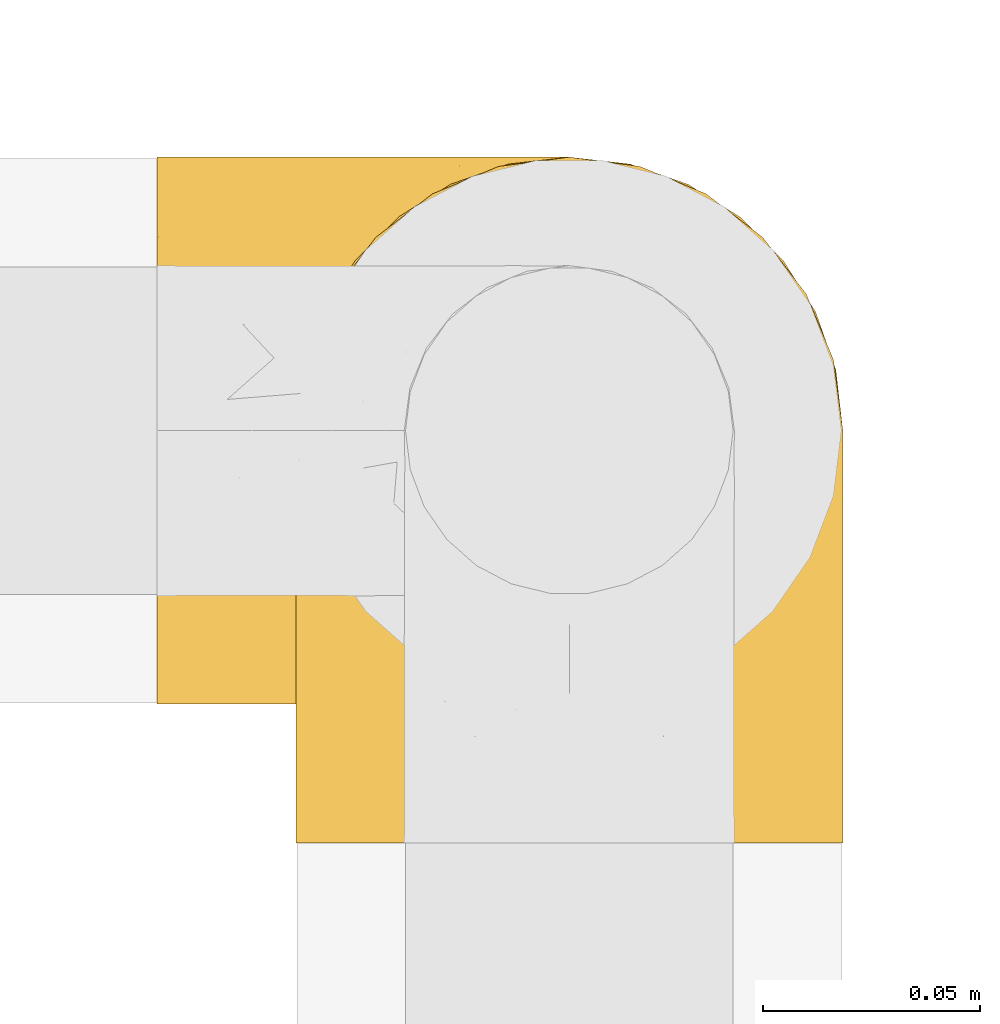
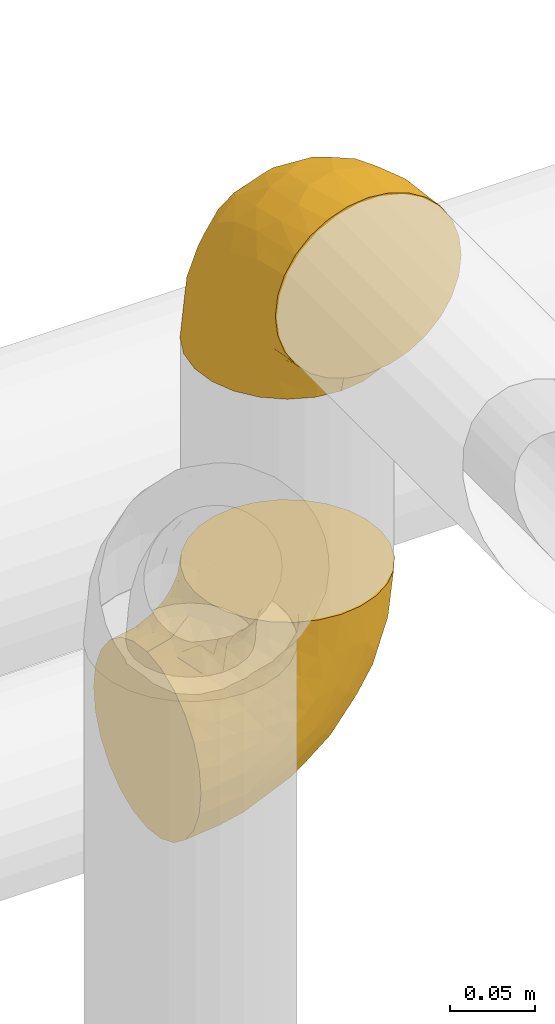
# One storey, part 122 of 827: 2 coverings.
"""IFC2X3 building model written with IfcOpenShell, lengths in millimetres."""

import ifcopenshell
import ifcopenshell.guid

model = None  # the IFC model being written
_history = None  # IfcOwnerHistory: only IFC2X3 demands one
_inside = {}  # id of a spatial element -> (the spatial element, [elements in it])
_under = {}  # id of a project, library or spatial element -> (it, [spatial elements below it])
_declared = {}  # id of a project -> (the project, [libraries it declares])
_typed = {}  # id of a type object -> (the type object, [elements of that type])
_made_of = {}  # id of a material, layer set ... -> (it, [elements and type objects made of it])


def new_model(schema):
    """Start an empty IFC model of exactly this schema.

    Asked for "IFC4X3", IfcOpenShell would pick the latest addendum, in which some entities
    have other attributes; the version numbers below select the first issue.
    IFC2X3 requires an IfcOwnerHistory on every rooted entity: one is made here for all.
    """
    global model, _history
    if schema == "IFC4X3":
        model = ifcopenshell.file(schema_version=(4, 3, 0, 0))
    else:
        model = ifcopenshell.file(schema=schema)
    _inside.clear()
    _under.clear()
    _declared.clear()
    _typed.clear()
    _made_of.clear()
    _history = None
    if model.schema == "IFC2X3":
        org = make("IfcOrganization", Name="unknown")
        user = make(
            "IfcPersonAndOrganization",
            ThePerson=make("IfcPerson", FamilyName="unknown"),
            TheOrganization=org,
        )
        app = make(
            "IfcApplication",
            ApplicationDeveloper=org,
            Version="unknown",
            ApplicationFullName="unknown",
            ApplicationIdentifier="unknown",
        )
        _history = make(
            "IfcOwnerHistory",
            OwningUser=user,
            OwningApplication=app,
            ChangeAction="ADDED",
            CreationDate=0,
        )
    return model


def make(cls, **values):
    """One entity of the class cls with the attributes given. An attribute that is None is left unset."""
    return model.create_entity(
        cls, **{name: value for name, value in values.items() if value is not None}
    )


def entity(cls, *values):
    """Any entity or typed value of the class cls, its attributes in the order of the schema. None: left unset."""
    e = model.create_entity(cls)
    for i, value in enumerate(values):
        if value is not None:
            e[i] = value
    return e


def rooted(cls, **values):
    """An entity with a GlobalId (a new one), such as an element, a storey or a relation."""
    return make(cls, GlobalId=ifcopenshell.guid.new(), OwnerHistory=_history, **values)


def si_unit(unit_type, name, prefix=None):
    """IfcSIUnit, for example si_unit("LENGTHUNIT", "METRE", prefix="MILLI")."""
    return make("IfcSIUnit", UnitType=unit_type, Prefix=prefix, Name=name)


def converted_unit(unit_type, name, factor, base, dimensions=None, offset=None):
    """IfcConversionBasedUnit, such as the inch: factor (a typed value) times the base unit."""
    return make(
        "IfcConversionBasedUnit"
        if offset is None
        else "IfcConversionBasedUnitWithOffset",
        ConversionOffset=offset,
        Dimensions=None
        if dimensions is None
        else entity("IfcDimensionalExponents", *dimensions),
        UnitType=unit_type,
        Name=name,
        ConversionFactor=make(
            "IfcMeasureWithUnit", ValueComponent=factor, UnitComponent=base
        ),
    )


def derived_unit(unit_type, elements):
    """IfcDerivedUnit: a product of units, each with its exponent."""
    return make(
        "IfcDerivedUnit",
        Elements=[
            make("IfcDerivedUnitElement", Unit=unit, Exponent=power)
            for unit, power in elements
        ],
        UnitType=unit_type,
    )


def assignment(units):
    """IfcUnitAssignment: the units of a project."""
    return None if units is None else make("IfcUnitAssignment", Units=units)


def point(xyz):
    """IfcCartesianPoint."""
    return None if xyz is None else make("IfcCartesianPoint", Coordinates=xyz)


def direction(xyz):
    """IfcDirection."""
    return None if xyz is None else make("IfcDirection", DirectionRatios=xyz)


def frame(location, z_axis=None, x_axis=None):
    """IfcAxis2Placement3D, a coordinate frame: its origin and axes. An axis left out is left unset."""
    return make(
        "IfcAxis2Placement3D",
        Location=point(location),
        Axis=direction(z_axis),
        RefDirection=direction(x_axis),
    )


def origin():
    """The frame at (0, 0, 0) with its axes left unset."""
    return frame((0.0, 0.0, 0.0))


def place(relative_to, where):
    """IfcLocalPlacement: puts the frame where relative to a parent placement (None: the world)."""
    return make(
        "IfcLocalPlacement", PlacementRelTo=relative_to, RelativePlacement=where
    )


def context(
    kind, dimensions, precision=None, world=None, true_north=None, identifier=None
):
    """IfcGeometricRepresentationContext, for example the 3D "Model" context."""
    return make(
        "IfcGeometricRepresentationContext",
        ContextIdentifier=identifier,
        ContextType=kind,
        CoordinateSpaceDimension=dimensions,
        Precision=precision,
        WorldCoordinateSystem=world,
        TrueNorth=true_north,
    )


def subcontext(parent, identifier, kind, view, scale=None):
    """IfcGeometricRepresentationSubContext, for example "Body" below "Model"."""
    return make(
        "IfcGeometricRepresentationSubContext",
        ContextIdentifier=identifier,
        ContextType=kind,
        ParentContext=parent,
        TargetScale=scale,
        TargetView=view,
    )


def project(units=None, contexts=None):
    """IfcProject with its units and contexts."""
    return rooted(
        "IfcProject",
        Name="project",
        RepresentationContexts=contexts,
        UnitsInContext=assignment(units),
    )


def spatial(cls, under=None, at=None, **own):
    """A site, building, storey or space (cls), placed at a placement, below another one or the project."""
    s = rooted(cls, ObjectPlacement=at, **own)
    if under is not None:
        _under.setdefault(under.id(), (under, []))[1].append(s)
    return s


def faces_of(points, faces, orient=None, outer=None):
    """IfcFace entities. A face is a list of loops; a loop is a list of indices into points, from 0.

    orient and outer hold one flag for each loop. By default every Orientation is true, the
    first loop of a face is its IfcFaceOuterBound and the others are IfcFaceBound.
    """
    made = []
    for i, loops in enumerate(faces):
        bounds = []
        for j, loop in enumerate(loops):
            is_outer = j == 0 if outer is None else outer[i][j]
            bounds.append(
                make(
                    "IfcFaceOuterBound" if is_outer else "IfcFaceBound",
                    Bound=make("IfcPolyLoop", Polygon=[points[k] for k in loop]),
                    Orientation=True if orient is None else orient[i][j],
                )
            )
        made.append(make("IfcFace", Bounds=bounds))
    return made


def faceted_brep(points, faces, orient=None, outer=None, voids=None):
    """IfcFacetedBrep: a solid bounded by flat faces; with voids (closed shells), ...WithVoids."""
    shared = [point(p) for p in points]
    hull = make("IfcClosedShell", CfsFaces=faces_of(shared, faces, orient, outer))
    if voids is None:
        return make("IfcFacetedBrep", Outer=hull)
    return make(
        "IfcFacetedBrepWithVoids",
        Outer=hull,
        Voids=[
            make(cls, CfsFaces=faces_of(shared, fs, o, b)) for cls, fs, o, b in voids
        ],
    )


def shape(context_of_items, identifier, shape_type, items):
    """IfcShapeRepresentation: the items that make up one representation, for example the "Body"."""
    return make(
        "IfcShapeRepresentation",
        ContextOfItems=context_of_items,
        RepresentationIdentifier=identifier,
        RepresentationType=shape_type,
        Items=items,
    )


def made_of(thing, what):
    """Note that an element or type object is made of a material, layer set ...; save() writes the relation."""
    if what is not None:
        _made_of.setdefault(what.id(), (what, []))[1].append(thing)
    return thing


def element(
    cls,
    number,
    at=None,
    inside=None,
    cuts=None,
    type_object=None,
    material=None,
    context=None,
    identifier="Body",
    shape_type=None,
    held_by="IfcProductDefinitionShape",
    body=None,
    shapes=None,
    **own,
):
    """One element of the class cls, such as IfcWall. Its Tag is "e" and its number.

    at: its placement. inside: the storey or other place that contains it. cuts: it is an
    opening in that element (IfcRelVoidsElement). A single representation is given by context,
    identifier, shape_type and body (its items); several are given by shapes. held_by: the class
    of the entity that holds the representations. save() writes the other relations.
    """
    e = rooted(cls, Tag="e%d" % number, ObjectPlacement=at, **own)
    if body is not None:
        shapes = [shape(context, identifier, shape_type, body)]
    if shapes is not None:
        e.Representation = make(held_by, Representations=shapes)
    if inside is not None:
        _inside.setdefault(inside.id(), (inside, []))[1].append(e)
    if cuts is not None:
        rooted(
            "IfcRelVoidsElement", RelatingBuildingElement=cuts, RelatedOpeningElement=e
        )
    if type_object is not None:
        _typed.setdefault(type_object.id(), (type_object, []))[1].append(e)
    return made_of(e, material)


def aggregate(whole, parts):
    """IfcRelAggregates: a whole, such as a stair, and the parts it consists of."""
    return rooted("IfcRelAggregates", RelatingObject=whole, RelatedObjects=parts)


def save(model, path):
    """Write the relations noted so far, then the file.

    IfcRelAggregates (storeys below a building ...), IfcRelContainedInSpatialStructure (elements
    in a storey), IfcRelDefinesByType, IfcRelAssociatesMaterial and IfcRelDeclares: one each for
    every whole, place, type object, material and project.
    """
    for whole, parts in _under.values():
        aggregate(whole, parts)
    for where, things in _inside.values():
        rooted(
            "IfcRelContainedInSpatialStructure",
            RelatedElements=things,
            RelatingStructure=where,
        )
    for kind, things in _typed.values():
        rooted("IfcRelDefinesByType", RelatedObjects=things, RelatingType=kind)
    for what, things in _made_of.values():
        rooted("IfcRelAssociatesMaterial", RelatedObjects=things, RelatingMaterial=what)
    for by, libraries in _declared.values():
        rooted("IfcRelDeclares", RelatingContext=by, RelatedDefinitions=libraries)
    model.write(path)


model = new_model("IFC2X3")

# Units and contexts
model_context = context("Model", 3, precision=0.01, world=origin(), true_north=direction((6.12303176911189e-17, 1.0)))
body_context = subcontext(model_context, "Body", "Model", "MODEL_VIEW")
ifc_project = project(units=[si_unit("LENGTHUNIT", "METRE", prefix="MILLI"), si_unit("AREAUNIT", "SQUARE_METRE"), si_unit("VOLUMEUNIT", "CUBIC_METRE"), converted_unit("PLANEANGLEUNIT", "DEGREE", entity("IfcRatioMeasure", 0.0174532925199433), si_unit("PLANEANGLEUNIT", "RADIAN"), dimensions=[0, 0, 0, 0, 0, 0, 0]), si_unit("MASSUNIT", "GRAM", prefix="KILO"), derived_unit("MASSDENSITYUNIT", [(si_unit("MASSUNIT", "GRAM", prefix="KILO"), 1), (si_unit("LENGTHUNIT", "METRE"), -3)]), derived_unit("MOMENTOFINERTIAUNIT", [(si_unit("LENGTHUNIT", "METRE"), 4)]), si_unit("TIMEUNIT", "SECOND"), si_unit("FREQUENCYUNIT", "HERTZ"), si_unit("THERMODYNAMICTEMPERATUREUNIT", "DEGREE_CELSIUS"), derived_unit("THERMALTRANSMITTANCEUNIT", [(si_unit("MASSUNIT", "GRAM", prefix="KILO"), 1), (si_unit("THERMODYNAMICTEMPERATUREUNIT", "KELVIN"), -1), (si_unit("TIMEUNIT", "SECOND"), -3)]), derived_unit("VOLUMETRICFLOWRATEUNIT", [(si_unit("LENGTHUNIT", "METRE"), 3), (si_unit("TIMEUNIT", "SECOND"), -1)]), derived_unit("MASSFLOWRATEUNIT", [(si_unit("MASSUNIT", "GRAM", prefix="KILO"), 1), (si_unit("TIMEUNIT", "SECOND"), -1)]), derived_unit("ROTATIONALFREQUENCYUNIT", [(si_unit("TIMEUNIT", "SECOND"), -1)]), si_unit("ELECTRICCURRENTUNIT", "AMPERE"), si_unit("ELECTRICVOLTAGEUNIT", "VOLT"), si_unit("POWERUNIT", "WATT"), si_unit("FORCEUNIT", "NEWTON", prefix="KILO"), si_unit("ILLUMINANCEUNIT", "LUX"), si_unit("LUMINOUSFLUXUNIT", "LUMEN"), si_unit("LUMINOUSINTENSITYUNIT", "CANDELA"), derived_unit("USERDEFINED", [(si_unit("MASSUNIT", "GRAM", prefix="KILO"), -1), (si_unit("LENGTHUNIT", "METRE"), -2), (si_unit("TIMEUNIT", "SECOND"), 3), (si_unit("LUMINOUSFLUXUNIT", "LUMEN"), 1)]), derived_unit("LINEARVELOCITYUNIT", [(si_unit("LENGTHUNIT", "METRE"), 1), (si_unit("TIMEUNIT", "SECOND"), -1)]), si_unit("PRESSUREUNIT", "PASCAL"), derived_unit("USERDEFINED", [(si_unit("LENGTHUNIT", "METRE"), -2), (si_unit("MASSUNIT", "GRAM", prefix="KILO"), 1), (si_unit("TIMEUNIT", "SECOND"), -2)]), derived_unit("LINEARFORCEUNIT", [(si_unit("MASSUNIT", "GRAM", prefix="KILO"), 1), (si_unit("LENGTHUNIT", "METRE"), 1), (si_unit("TIMEUNIT", "SECOND"), -2), (si_unit("LENGTHUNIT", "METRE"), -1)]), derived_unit("PLANARFORCEUNIT", [(si_unit("MASSUNIT", "GRAM", prefix="KILO"), 1), (si_unit("LENGTHUNIT", "METRE"), 1), (si_unit("TIMEUNIT", "SECOND"), -2), (si_unit("LENGTHUNIT", "METRE"), -2)])], contexts=[model_context])

# Site, building, storey
site_placement = place(None, origin())
site = spatial("IfcSite", under=ifc_project, at=site_placement, CompositionType="ELEMENT")
building_placement = place(site_placement, origin())
building = spatial("IfcBuilding", under=site, at=building_placement, CompositionType="ELEMENT")
storey_placement = place(building_placement, frame((0.0, 0.0, 28200.0)))
storey = spatial("IfcBuildingStorey", under=building, at=storey_placement, Name="08", CompositionType="ELEMENT", Elevation=28200.0)

# Coverings
covering_1_placement = place(storey_placement, frame((26771.04, 12005.36, 3035.35)))
element("IfcCovering", 1, at=covering_1_placement, inside=storey, Name=":ADSK_", ObjectType=":ADSK_", PredefinedType="INSULATION", context=body_context, shape_type="Brep", body=[
    faceted_brep([(110.62, 3.18, 159.65), (123.95, 7.84, 159.65), (135.9, 15.35, 159.65), (145.89, 25.33, 159.65), (153.4, 37.29, 159.65), (158.06, 50.61, 159.65), (159.65, 64.65, 159.65), (158.06, 78.67, 159.65), (153.4, 92.0, 159.65), (145.89, 103.95, 159.65), (135.91, 113.94, 159.65), (123.95, 121.45, 159.65), (110.63, 126.11, 159.65), (96.6, 127.7, 159.65), (82.57, 126.11, 159.65), (69.24, 121.45, 159.65), (57.29, 113.94, 159.65), (47.3, 103.96, 159.65), (39.79, 92.0, 159.65), (35.13, 78.68, 159.65), (33.55, 64.65, 159.65), (35.13, 50.62, 159.65), (39.79, 37.29, 159.65), (47.3, 25.34, 159.65), (57.28, 15.35, 159.65), (69.24, 7.84, 159.65), (82.56, 3.18, 159.65), (96.6, 1.6, 159.65), (1.6, 64.65, 127.7), (1.6, 80.96, 125.55), (1.6, 96.17, 119.25), (1.6, 109.23, 109.23), (1.6, 119.25, 96.17), (1.6, 125.55, 80.96), (1.6, 126.29, 75.35), (1.6, 127.7, 64.65), (1.6, 125.55, 48.33), (1.6, 119.25, 33.12), (1.6, 109.23, 20.06), (1.6, 96.17, 10.04), (1.6, 80.96, 3.74), (1.6, 64.65, 1.6), (1.6, 48.33, 3.74), (1.6, 33.12, 10.04), (1.6, 20.06, 20.06), (1.6, 10.04, 33.12), (1.6, 3.74, 48.33), (1.6, 1.6, 64.65), (1.6, 3.01, 75.35), (1.6, 3.74, 80.96), (1.6, 10.04, 96.17), (1.6, 20.06, 109.23), (1.6, 33.12, 119.25), (1.6, 48.33, 125.55), (30.13, 28.19, 16.01), (39.4, 42.57, 10.29), (62.65, 30.59, 24.76), (28.52, 53.36, 4.94), (42.5, 64.65, 6.98), (115.57, 15.9, 87.32), (98.94, 18.23, 62.3), (111.29, 32.42, 58.52), (95.5, 45.22, 36.35), (80.62, 64.65, 22.77), (113.35, 64.65, 47.89), (43.71, 9.73, 40.91), (70.76, 16.54, 42.82), (62.71, 6.44, 57.25), (33.16, 4.21, 51.19), (53.41, 2.65, 66.64), (130.65, 23.51, 98.56), (137.68, 35.48, 94.44), (146.84, 33.22, 123.53), (66.58, 42.18, 20.12), (57.7, 53.52, 12.95), (39.88, 17.3, 28.48), (154.26, 64.65, 118.74), (152.07, 45.71, 121.88), (125.54, 48.33, 65.08), (142.81, 50.95, 92.08), (103.99, 6.44, 98.53), (79.4, 3.41, 81.84), (88.81, 8.33, 72.43), (104.86, 2.62, 134.31), (117.38, 6.65, 129.11), (57.43, 1.6, 82.79), (44.19, 1.6, 76.04), (30.95, 1.6, 69.29), (139.96, 22.17, 129.58), (127.03, 14.22, 115.86), (87.17, 26.48, 42.36), (78.45, 1.6, 103.81), (73.2, 1.6, 98.55), (67.94, 1.6, 93.3), (94.63, 1.6, 147.25), (93.29, 1.6, 138.77), (91.95, 1.6, 130.29), (94.6, 2.65, 107.83), (85.2, 1.6, 117.05), (138.47, 64.65, 80.62), (13.99, 1.6, 66.61), (40.46, 16.24, 121.29), (32.36, 27.48, 128.09), (28.71, 20.83, 118.04), (15.53, 3.08, 79.47), (29.06, 6.64, 94.94), (40.03, 2.74, 86.01), (45.36, 3.84, 94.69), (26.46, 3.28, 83.06), (47.56, 5.99, 104.39), (36.28, 10.3, 107.01), (55.57, 15.78, 148.3), (45.02, 24.69, 143.82), (57.55, 11.25, 134.19), (11.56, 27.69, 116.87), (19.2, 19.31, 111.58), (10.07, 37.19, 122.36), (21.04, 33.01, 124.16), (15.52, 8.24, 94.28), (13.84, 49.89, 128.25), (32.67, 50.1, 146.72), (24.86, 48.9, 134.92), (34.31, 36.15, 138.87), (81.47, 2.54, 133.28), (71.26, 3.58, 121.77), (81.64, 3.12, 145.83), (29.26, 64.65, 143.67), (70.65, 6.01, 139.93), (31.93, 64.65, 153.63), (27.99, 37.71, 132.32), (41.71, 22.19, 132.59), (50.14, 13.01, 126.42), (17.57, 12.97, 102.97), (37.62, 38.95, 149.52), (60.48, 6.55, 120.88), (17.57, 64.65, 131.98), (56.96, 2.52, 96.12), (48.98, 9.45, 115.84), (57.29, 4.58, 108.2), (68.25, 2.83, 110.85), (10.07, 92.1, 122.36), (16.58, 101.63, 118.35), (13.84, 79.39, 128.25), (13.99, 127.7, 66.61), (32.67, 79.2, 146.72), (24.86, 80.4, 134.92), (67.81, 126.41, 110.73), (61.09, 122.74, 121.83), (71.26, 125.71, 121.77), (57.43, 127.7, 82.79), (44.19, 127.7, 76.04), (40.03, 126.55, 86.01), (57.55, 118.04, 134.19), (51.01, 117.36, 124.9), (42.79, 108.2, 132.35), (26.46, 126.01, 83.06), (29.06, 122.65, 94.94), (17.57, 116.32, 102.97), (19.2, 109.98, 111.58), (40.46, 113.06, 121.29), (28.84, 107.85, 118.82), (33.48, 102.33, 128.68), (15.52, 121.05, 94.28), (15.53, 126.21, 79.47), (36.28, 118.99, 107.01), (37.62, 90.34, 149.51), (21.04, 96.28, 124.16), (94.63, 127.7, 147.25), (93.29, 127.7, 138.77), (34.31, 93.14, 138.87), (45.03, 104.6, 143.82), (70.65, 123.28, 139.92), (81.47, 126.75, 133.28), (55.58, 113.51, 148.3), (91.95, 127.7, 130.29), (81.64, 126.17, 145.83), (27.86, 91.96, 131.94), (78.45, 127.7, 103.81), (85.2, 127.7, 117.05), (56.96, 126.77, 96.12), (45.36, 125.45, 94.69), (47.57, 123.3, 104.39), (48.27, 119.94, 114.83), (67.94, 127.7, 93.3), (57.3, 124.71, 108.2), (30.95, 127.7, 69.29), (62.65, 98.7, 24.76), (30.13, 101.1, 16.01), (39.88, 111.99, 28.48), (43.71, 119.56, 40.91), (39.4, 86.72, 10.29), (55.79, 75.78, 12.23), (28.41, 75.87, 4.91), (53.41, 126.64, 66.64), (104.86, 126.67, 134.31), (117.39, 122.63, 129.11), (103.99, 122.85, 98.53), (125.54, 80.96, 65.08), (111.29, 96.87, 58.52), (137.69, 93.81, 94.45), (94.6, 126.64, 107.83), (79.4, 125.88, 81.84), (33.16, 125.08, 51.19), (68.78, 86.22, 20.8), (130.66, 105.77, 98.56), (139.97, 107.12, 129.58), (148.6, 96.19, 131.93), (115.58, 113.39, 87.32), (127.03, 115.06, 115.86), (70.76, 112.75, 42.82), (95.5, 84.07, 36.35), (62.71, 122.85, 57.25), (88.81, 120.97, 72.43), (98.94, 111.06, 62.3), (89.09, 96.3, 38.39), (78.72, 75.94, 22.86), (142.21, 80.53, 92.06), (152.07, 83.57, 121.88)], [[[0, 1, 2, 3, 4, 5, 6, 7, 8, 9, 10, 11, 12, 13, 14, 15, 16, 17, 18, 19, 20, 21, 22, 23, 24, 25, 26, 27]], [[28, 29, 30, 31, 32, 33, 34, 35, 36, 37, 38, 39, 40, 41, 42, 43, 44, 45, 46, 47, 48, 49, 50, 51, 52, 53]], [[54, 55, 56]], [[57, 41, 58]], [[59, 60, 61]], [[62, 63, 64]], [[65, 66, 67]], [[68, 67, 69]], [[70, 71, 72]], [[55, 73, 56]], [[43, 42, 55]], [[55, 74, 73]], [[44, 75, 45]], [[44, 43, 54]], [[76, 5, 77]], [[71, 78, 79]], [[45, 75, 65]], [[46, 68, 47]], [[80, 81, 82]], [[0, 83, 84]], [[69, 85, 86, 87]], [[69, 81, 85]], [[84, 1, 0]], [[2, 88, 3]], [[4, 3, 72]], [[44, 54, 75]], [[5, 4, 77]], [[89, 2, 1]], [[72, 3, 88]], [[5, 76, 6]], [[70, 88, 89]], [[68, 65, 67]], [[88, 2, 89]], [[56, 90, 66]], [[64, 78, 62]], [[81, 91, 92, 93, 85]], [[83, 27, 94, 95, 96]], [[62, 61, 90]], [[97, 96, 98, 91]], [[80, 97, 81]], [[42, 57, 55]], [[62, 78, 61]], [[84, 89, 1]], [[78, 64, 99]], [[57, 74, 55]], [[76, 77, 79]], [[77, 72, 71]], [[82, 81, 67]], [[97, 83, 96]], [[80, 89, 84]], [[79, 78, 99]], [[71, 70, 61]], [[81, 97, 91]], [[83, 80, 84]], [[68, 87, 100, 47]], [[81, 69, 67]], [[68, 69, 87]], [[65, 46, 45]], [[65, 68, 46]], [[66, 65, 75]], [[56, 66, 75]], [[66, 60, 82]], [[71, 61, 78]], [[60, 66, 90]], [[83, 97, 80]], [[27, 83, 0]], [[59, 70, 89]], [[70, 59, 61]], [[89, 80, 59]], [[82, 59, 80]], [[55, 54, 43]], [[75, 54, 56]], [[66, 82, 67]], [[59, 82, 60]], [[41, 57, 42]], [[74, 57, 58]], [[58, 63, 74]], [[62, 74, 63]], [[74, 62, 73]], [[62, 56, 73]], [[4, 72, 77]], [[70, 72, 88]], [[76, 79, 99]], [[71, 79, 77]], [[62, 90, 56]], [[60, 90, 61]], [[101, 102, 103]], [[100, 87, 104]], [[105, 106, 107]], [[108, 104, 87]], [[107, 109, 110]], [[108, 87, 86]], [[111, 112, 113]], [[114, 51, 115]], [[116, 114, 117]], [[51, 50, 118]], [[119, 28, 53]], [[120, 121, 122]], [[98, 123, 124]], [[125, 96, 95]], [[116, 53, 52]], [[126, 121, 120]], [[104, 108, 118]], [[98, 124, 91]], [[25, 24, 127]], [[120, 128, 126]], [[122, 129, 102]], [[95, 94, 27, 26]], [[122, 102, 130]], [[125, 127, 123]], [[24, 111, 127]], [[21, 20, 128]], [[112, 130, 131]], [[48, 47, 100, 49]], [[132, 110, 115]], [[23, 111, 24]], [[129, 119, 117]], [[120, 133, 21]], [[112, 23, 22]], [[134, 113, 131]], [[121, 126, 135]], [[133, 112, 22]], [[128, 120, 21]], [[132, 51, 118]], [[120, 122, 133]], [[119, 121, 135]], [[129, 117, 102]], [[125, 26, 25]], [[26, 125, 95]], [[127, 125, 25]], [[28, 119, 135]], [[119, 53, 116]], [[127, 113, 124]], [[96, 125, 123]], [[112, 131, 113]], [[101, 103, 110]], [[85, 93, 136]], [[124, 123, 127]], [[98, 96, 123]], [[112, 111, 23]], [[127, 111, 113]], [[112, 133, 122]], [[21, 133, 22]], [[107, 110, 105]], [[110, 109, 137]], [[86, 106, 108]], [[138, 109, 136]], [[105, 118, 108]], [[107, 106, 85]], [[104, 50, 49]], [[124, 134, 139]], [[138, 93, 92]], [[92, 91, 139]], [[100, 104, 49]], [[118, 105, 132]], [[104, 118, 50]], [[110, 132, 105]], [[51, 132, 115]], [[108, 106, 105]], [[85, 106, 86]], [[114, 116, 52]], [[119, 116, 117]], [[51, 114, 52]], [[114, 115, 103]], [[117, 114, 103]], [[130, 102, 101]], [[117, 103, 102]], [[110, 103, 115]], [[130, 101, 131]], [[122, 130, 112]], [[101, 137, 131]], [[113, 134, 124]], [[137, 134, 131]], [[124, 139, 91]], [[134, 138, 139]], [[92, 139, 138]], [[110, 137, 101]], [[134, 137, 138]], [[136, 109, 107]], [[137, 109, 138]], [[85, 136, 107]], [[138, 136, 93]], [[122, 121, 129]], [[129, 121, 119]], [[30, 140, 141]], [[30, 29, 140]], [[28, 135, 142]], [[143, 35, 34, 33]], [[19, 144, 128]], [[126, 145, 135]], [[146, 147, 148]], [[149, 150, 151]], [[152, 153, 154]], [[155, 156, 151]], [[157, 31, 158]], [[159, 160, 161]], [[32, 162, 163]], [[158, 31, 30]], [[157, 164, 156]], [[126, 144, 145]], [[126, 128, 144]], [[18, 165, 19]], [[141, 166, 160]], [[14, 13, 167, 168]], [[163, 143, 33]], [[169, 165, 170]], [[18, 17, 170]], [[153, 159, 154]], [[142, 135, 145]], [[148, 171, 172]], [[159, 161, 154]], [[171, 152, 173]], [[173, 17, 16]], [[16, 15, 171]], [[158, 160, 164]], [[174, 175, 168]], [[173, 170, 17]], [[19, 128, 20]], [[174, 172, 175]], [[165, 169, 144]], [[162, 157, 156]], [[175, 172, 171]], [[144, 169, 145]], [[176, 169, 161]], [[166, 140, 142]], [[175, 171, 15]], [[168, 175, 14]], [[14, 175, 15]], [[142, 145, 176]], [[28, 142, 29]], [[148, 177, 146]], [[148, 178, 177]], [[152, 171, 148]], [[179, 180, 181]], [[164, 180, 156]], [[174, 178, 172]], [[148, 172, 178]], [[171, 173, 16]], [[170, 173, 152]], [[19, 165, 144]], [[170, 165, 18]], [[153, 182, 159]], [[146, 183, 184]], [[181, 180, 164]], [[180, 151, 156]], [[163, 155, 185]], [[155, 150, 185]], [[162, 156, 155]], [[143, 163, 185]], [[180, 179, 149]], [[32, 163, 33]], [[163, 162, 155]], [[31, 162, 32]], [[31, 157, 162]], [[164, 157, 158]], [[149, 151, 180]], [[155, 151, 150]], [[142, 140, 29]], [[141, 140, 166]], [[176, 145, 169]], [[30, 141, 158]], [[164, 160, 159]], [[158, 141, 160]], [[166, 161, 160]], [[154, 169, 170]], [[169, 154, 161]], [[152, 154, 170]], [[147, 152, 148]], [[153, 147, 182]], [[181, 182, 184]], [[164, 159, 182]], [[161, 166, 176]], [[142, 176, 166]], [[183, 146, 177]], [[184, 182, 147]], [[184, 147, 146]], [[152, 147, 153]], [[182, 181, 164]], [[179, 184, 183]], [[184, 179, 181]], [[149, 179, 183]], [[186, 187, 188]], [[37, 36, 189]], [[190, 191, 192]], [[193, 185, 150, 149]], [[194, 195, 196]], [[197, 198, 199]], [[200, 201, 177]], [[193, 202, 185]], [[203, 190, 186]], [[202, 189, 36]], [[41, 40, 192]], [[204, 205, 199]], [[9, 8, 206]], [[187, 190, 39]], [[40, 39, 190]], [[38, 37, 188]], [[207, 208, 204]], [[202, 35, 143, 185]], [[39, 38, 187]], [[195, 11, 208]], [[201, 149, 183, 177]], [[188, 189, 209]], [[197, 64, 210]], [[186, 188, 209]], [[13, 12, 194]], [[211, 201, 212]], [[12, 11, 195]], [[193, 201, 211]], [[212, 201, 196]], [[10, 208, 11]], [[213, 214, 209]], [[64, 63, 215]], [[216, 197, 199]], [[8, 217, 206]], [[7, 217, 8]], [[203, 191, 190]], [[7, 6, 76]], [[208, 205, 204]], [[205, 10, 9]], [[199, 205, 206]], [[7, 76, 217]], [[205, 208, 10]], [[216, 76, 99]], [[200, 177, 178, 174]], [[64, 197, 99]], [[63, 58, 191]], [[208, 196, 195]], [[196, 200, 194]], [[198, 197, 210]], [[216, 199, 217]], [[201, 193, 149]], [[202, 193, 211]], [[202, 211, 189]], [[35, 202, 36]], [[211, 212, 209]], [[37, 189, 188]], [[211, 209, 189]], [[213, 198, 214]], [[200, 174, 194]], [[201, 200, 196]], [[214, 198, 210]], [[213, 207, 198]], [[194, 174, 168, 167, 13]], [[195, 194, 12]], [[198, 204, 199]], [[204, 198, 207]], [[212, 207, 213]], [[196, 208, 207]], [[188, 187, 38]], [[190, 187, 186]], [[207, 212, 196]], [[209, 212, 213]], [[214, 203, 186]], [[191, 215, 63]], [[191, 203, 215]], [[192, 191, 58]], [[41, 192, 58]], [[190, 192, 40]], [[203, 210, 215]], [[64, 215, 210]], [[199, 206, 217]], [[9, 206, 205]], [[76, 216, 217]], [[99, 197, 216]], [[203, 214, 210]], [[209, 214, 186]]]),
])
covering_2_placement = place(storey_placement, frame((26802.99, 11973.41, 3353.4)))
element("IfcCovering", 2, at=covering_2_placement, inside=storey, Name=":ADSK_", ObjectType=":ADSK_", PredefinedType="INSULATION", context=body_context, shape_type="Brep", body=[
    faceted_brep([(126.11, 1.6, 110.62), (121.45, 1.6, 123.95), (113.94, 1.6, 135.9), (103.96, 1.6, 145.89), (92.0, 1.6, 153.4), (78.68, 1.6, 158.06), (64.65, 1.6, 159.65), (50.62, 1.6, 158.06), (37.29, 1.6, 153.4), (25.34, 1.6, 145.89), (15.35, 1.6, 135.91), (7.84, 1.6, 123.95), (3.18, 1.6, 110.63), (1.6, 1.6, 96.6), (3.18, 1.6, 82.57), (7.84, 1.6, 69.24), (15.35, 1.6, 57.29), (25.33, 1.6, 47.3), (37.29, 1.6, 39.79), (50.61, 1.6, 35.13), (64.65, 1.6, 33.55), (78.67, 1.6, 35.13), (92.0, 1.6, 39.79), (103.95, 1.6, 47.3), (113.94, 1.6, 57.28), (121.45, 1.6, 69.24), (126.11, 1.6, 82.56), (127.7, 1.6, 96.6), (64.65, 33.55, 1.6), (48.33, 35.69, 1.6), (33.12, 41.99, 1.6), (20.06, 52.01, 1.6), (10.04, 65.07, 1.6), (3.74, 80.28, 1.6), (3.01, 85.89, 1.6), (1.6, 96.6, 1.6), (3.74, 112.91, 1.6), (10.04, 128.12, 1.6), (20.06, 141.18, 1.6), (33.12, 151.2, 1.6), (48.33, 157.5, 1.6), (64.65, 159.65, 1.6), (80.96, 157.5, 1.6), (96.17, 151.2, 1.6), (109.23, 141.18, 1.6), (119.25, 128.12, 1.6), (125.55, 112.91, 1.6), (127.7, 96.6, 1.6), (126.29, 85.89, 1.6), (125.55, 80.28, 1.6), (119.25, 65.07, 1.6), (109.23, 52.01, 1.6), (96.17, 41.99, 1.6), (80.96, 35.69, 1.6), (101.1, 145.23, 30.13), (86.72, 150.95, 39.4), (98.7, 136.48, 62.65), (75.93, 156.3, 28.52), (64.65, 154.26, 42.5), (113.39, 73.92, 115.57), (111.06, 98.94, 98.94), (96.87, 102.72, 111.29), (84.07, 124.89, 95.5), (64.65, 138.47, 80.62), (64.65, 113.35, 113.35), (119.56, 120.33, 43.71), (112.75, 118.42, 70.76), (122.85, 103.99, 62.71), (125.08, 110.05, 33.16), (126.64, 94.6, 53.41), (105.78, 62.68, 130.65), (93.81, 66.8, 137.68), (96.07, 37.71, 146.84), (87.11, 141.12, 66.58), (75.77, 148.29, 57.7), (111.99, 132.76, 39.88), (64.65, 42.5, 154.26), (83.58, 39.36, 152.07), (80.96, 96.16, 125.54), (78.34, 69.16, 142.81), (122.85, 62.71, 103.99), (125.88, 79.4, 79.4), (120.97, 88.81, 88.81), (126.67, 26.93, 104.86), (122.64, 32.13, 117.38), (127.7, 78.45, 57.43), (127.7, 85.2, 44.19), (127.7, 91.95, 30.95), (107.12, 31.66, 139.96), (115.07, 45.38, 127.03), (102.81, 118.88, 87.17), (127.7, 57.43, 78.45), (127.7, 62.69, 73.2), (127.7, 67.94, 67.94), (127.7, 13.99, 94.63), (127.7, 22.47, 93.29), (127.7, 30.95, 91.95), (126.64, 53.41, 94.6), (127.7, 44.19, 85.2), (64.65, 80.62, 138.47), (127.7, 94.63, 13.99), (113.05, 39.95, 40.46), (101.81, 33.15, 32.36), (108.46, 43.2, 28.71), (126.21, 81.77, 15.53), (122.65, 66.3, 29.06), (126.55, 75.23, 40.03), (125.45, 66.55, 45.36), (126.01, 78.18, 26.46), (123.3, 56.85, 47.56), (118.99, 54.23, 36.28), (113.51, 12.94, 55.57), (104.6, 17.42, 45.02), (118.04, 27.05, 57.55), (101.6, 44.37, 11.56), (109.98, 49.66, 19.2), (92.1, 38.88, 10.07), (96.28, 37.08, 21.04), (121.05, 66.96, 15.52), (79.4, 32.99, 13.84), (79.19, 14.52, 32.67), (80.39, 26.32, 24.86), (93.14, 22.37, 34.31), (126.75, 27.96, 81.47), (125.71, 39.47, 71.26), (126.17, 15.41, 81.64), (64.65, 17.57, 29.26), (123.28, 21.32, 70.65), (64.65, 7.61, 31.93), (91.58, 28.92, 27.99), (107.1, 28.65, 41.71), (116.28, 34.82, 50.14), (116.32, 58.27, 17.57), (90.34, 11.73, 37.62), (122.74, 40.36, 60.48), (64.65, 29.26, 17.57), (126.77, 65.12, 56.96), (119.84, 45.4, 48.98), (124.71, 53.05, 57.29), (126.47, 50.39, 68.25), (37.19, 38.88, 10.07), (27.66, 42.9, 16.58), (49.9, 32.99, 13.84), (1.6, 94.63, 13.99), (50.1, 14.52, 32.67), (48.89, 26.32, 24.86), (2.88, 50.51, 67.81), (6.55, 39.41, 61.09), (3.58, 39.47, 71.26), (1.6, 78.45, 57.43), (1.6, 85.2, 44.19), (2.74, 75.23, 40.03), (11.25, 27.05, 57.55), (11.93, 36.34, 51.01), (21.09, 28.89, 42.79), (3.28, 78.18, 26.46), (6.64, 66.3, 29.06), (12.97, 58.27, 17.57), (19.31, 49.66, 19.2), (16.23, 39.95, 40.46), (21.44, 42.42, 28.84), (26.96, 32.56, 33.48), (8.24, 66.96, 15.52), (3.08, 81.77, 15.53), (10.3, 54.23, 36.28), (38.95, 11.73, 37.62), (33.01, 37.08, 21.04), (1.6, 13.99, 94.63), (1.6, 22.47, 93.29), (36.15, 22.37, 34.31), (24.69, 17.42, 45.03), (6.01, 21.32, 70.65), (2.54, 27.96, 81.47), (15.78, 12.94, 55.58), (1.6, 30.95, 91.95), (3.12, 15.41, 81.64), (37.33, 29.3, 27.86), (1.6, 57.43, 78.45), (1.6, 44.19, 85.2), (2.52, 65.12, 56.96), (3.84, 66.55, 45.36), (5.99, 56.85, 47.57), (9.35, 46.41, 48.27), (1.6, 67.94, 67.94), (4.58, 53.04, 57.3), (1.6, 91.95, 30.95), (30.59, 136.48, 62.65), (28.19, 145.23, 30.13), (17.3, 132.76, 39.88), (9.73, 120.33, 43.71), (42.57, 150.95, 39.4), (53.51, 149.01, 55.79), (53.42, 156.33, 28.41), (2.65, 94.6, 53.41), (2.62, 26.93, 104.86), (6.66, 32.14, 117.39), (6.44, 62.71, 103.99), (48.33, 96.16, 125.54), (32.42, 102.72, 111.29), (35.49, 66.79, 137.69), (2.65, 53.41, 94.6), (3.41, 79.4, 79.4), (4.21, 110.05, 33.16), (43.07, 140.44, 68.78), (23.52, 62.68, 130.66), (22.18, 31.66, 139.97), (33.1, 29.31, 148.6), (15.9, 73.92, 115.58), (14.23, 45.39, 127.03), (16.54, 118.42, 70.76), (45.22, 124.89, 95.5), (6.44, 103.99, 62.71), (8.33, 88.81, 88.81), (18.23, 98.94, 98.94), (32.99, 122.85, 89.09), (53.35, 138.38, 78.72), (48.76, 69.18, 142.21), (45.72, 39.36, 152.07)], [[[0, 1, 2, 3, 4, 5, 6, 7, 8, 9, 10, 11, 12, 13, 14, 15, 16, 17, 18, 19, 20, 21, 22, 23, 24, 25, 26, 27]], [[28, 29, 30, 31, 32, 33, 34, 35, 36, 37, 38, 39, 40, 41, 42, 43, 44, 45, 46, 47, 48, 49, 50, 51, 52, 53]], [[54, 55, 56]], [[57, 41, 58]], [[59, 60, 61]], [[62, 63, 64]], [[65, 66, 67]], [[68, 67, 69]], [[70, 71, 72]], [[55, 73, 56]], [[43, 42, 55]], [[55, 74, 73]], [[44, 75, 45]], [[44, 43, 54]], [[76, 5, 77]], [[71, 78, 79]], [[45, 75, 65]], [[46, 68, 47]], [[80, 81, 82]], [[0, 83, 84]], [[69, 85, 86, 87]], [[69, 81, 85]], [[84, 1, 0]], [[2, 88, 3]], [[4, 3, 72]], [[44, 54, 75]], [[5, 4, 77]], [[89, 2, 1]], [[72, 3, 88]], [[5, 76, 6]], [[70, 88, 89]], [[68, 65, 67]], [[88, 2, 89]], [[56, 90, 66]], [[64, 78, 62]], [[81, 91, 92, 93, 85]], [[83, 27, 94, 95, 96]], [[62, 61, 90]], [[97, 96, 98, 91]], [[80, 97, 81]], [[42, 57, 55]], [[62, 78, 61]], [[84, 89, 1]], [[78, 64, 99]], [[57, 74, 55]], [[76, 77, 79]], [[77, 72, 71]], [[82, 81, 67]], [[97, 83, 96]], [[80, 89, 84]], [[79, 78, 99]], [[71, 70, 61]], [[81, 97, 91]], [[83, 80, 84]], [[68, 87, 100, 47]], [[81, 69, 67]], [[68, 69, 87]], [[65, 46, 45]], [[65, 68, 46]], [[66, 65, 75]], [[56, 66, 75]], [[66, 60, 82]], [[71, 61, 78]], [[60, 66, 90]], [[83, 97, 80]], [[27, 83, 0]], [[59, 70, 89]], [[70, 59, 61]], [[89, 80, 59]], [[82, 59, 80]], [[55, 54, 43]], [[75, 54, 56]], [[66, 82, 67]], [[59, 82, 60]], [[41, 57, 42]], [[74, 57, 58]], [[58, 63, 74]], [[62, 74, 63]], [[74, 62, 73]], [[62, 56, 73]], [[4, 72, 77]], [[70, 72, 88]], [[76, 79, 99]], [[71, 79, 77]], [[62, 90, 56]], [[60, 90, 61]], [[101, 102, 103]], [[100, 87, 104]], [[105, 106, 107]], [[108, 104, 87]], [[107, 109, 110]], [[108, 87, 86]], [[111, 112, 113]], [[114, 51, 115]], [[116, 114, 117]], [[51, 50, 118]], [[119, 28, 53]], [[120, 121, 122]], [[98, 123, 124]], [[125, 96, 95]], [[116, 53, 52]], [[126, 121, 120]], [[104, 108, 118]], [[98, 124, 91]], [[25, 24, 127]], [[120, 128, 126]], [[122, 129, 102]], [[95, 94, 27, 26]], [[122, 102, 130]], [[125, 127, 123]], [[24, 111, 127]], [[21, 20, 128]], [[112, 130, 131]], [[48, 47, 100, 49]], [[132, 110, 115]], [[23, 111, 24]], [[129, 119, 117]], [[120, 133, 21]], [[112, 23, 22]], [[134, 113, 131]], [[121, 126, 135]], [[133, 112, 22]], [[128, 120, 21]], [[132, 51, 118]], [[120, 122, 133]], [[119, 121, 135]], [[129, 117, 102]], [[125, 26, 25]], [[26, 125, 95]], [[127, 125, 25]], [[28, 119, 135]], [[119, 53, 116]], [[127, 113, 124]], [[96, 125, 123]], [[112, 131, 113]], [[101, 103, 110]], [[85, 93, 136]], [[124, 123, 127]], [[98, 96, 123]], [[112, 111, 23]], [[127, 111, 113]], [[112, 133, 122]], [[21, 133, 22]], [[107, 110, 105]], [[110, 109, 137]], [[86, 106, 108]], [[138, 109, 136]], [[105, 118, 108]], [[107, 106, 85]], [[104, 50, 49]], [[124, 134, 139]], [[138, 93, 92]], [[92, 91, 139]], [[100, 104, 49]], [[118, 105, 132]], [[104, 118, 50]], [[110, 132, 105]], [[51, 132, 115]], [[108, 106, 105]], [[85, 106, 86]], [[114, 116, 52]], [[119, 116, 117]], [[51, 114, 52]], [[114, 115, 103]], [[117, 114, 103]], [[130, 102, 101]], [[117, 103, 102]], [[110, 103, 115]], [[130, 101, 131]], [[122, 130, 112]], [[101, 137, 131]], [[113, 134, 124]], [[137, 134, 131]], [[124, 139, 91]], [[134, 138, 139]], [[92, 139, 138]], [[110, 137, 101]], [[134, 137, 138]], [[136, 109, 107]], [[137, 109, 138]], [[85, 136, 107]], [[138, 136, 93]], [[122, 121, 129]], [[129, 121, 119]], [[30, 140, 141]], [[30, 29, 140]], [[28, 135, 142]], [[143, 35, 34, 33]], [[19, 144, 128]], [[126, 145, 135]], [[146, 147, 148]], [[149, 150, 151]], [[152, 153, 154]], [[155, 156, 151]], [[157, 31, 158]], [[159, 160, 161]], [[32, 162, 163]], [[158, 31, 30]], [[157, 164, 156]], [[126, 144, 145]], [[126, 128, 144]], [[18, 165, 19]], [[141, 166, 160]], [[14, 13, 167, 168]], [[163, 143, 33]], [[169, 165, 170]], [[18, 17, 170]], [[153, 159, 154]], [[142, 135, 145]], [[148, 171, 172]], [[159, 161, 154]], [[171, 152, 173]], [[173, 17, 16]], [[16, 15, 171]], [[158, 160, 164]], [[174, 175, 168]], [[173, 170, 17]], [[19, 128, 20]], [[174, 172, 175]], [[165, 169, 144]], [[162, 157, 156]], [[175, 172, 171]], [[144, 169, 145]], [[176, 169, 161]], [[166, 140, 142]], [[175, 171, 15]], [[168, 175, 14]], [[14, 175, 15]], [[142, 145, 176]], [[28, 142, 29]], [[148, 177, 146]], [[148, 178, 177]], [[152, 171, 148]], [[179, 180, 181]], [[164, 180, 156]], [[174, 178, 172]], [[148, 172, 178]], [[171, 173, 16]], [[170, 173, 152]], [[19, 165, 144]], [[170, 165, 18]], [[153, 182, 159]], [[146, 183, 184]], [[181, 180, 164]], [[180, 151, 156]], [[163, 155, 185]], [[155, 150, 185]], [[162, 156, 155]], [[143, 163, 185]], [[180, 179, 149]], [[32, 163, 33]], [[163, 162, 155]], [[31, 162, 32]], [[31, 157, 162]], [[164, 157, 158]], [[149, 151, 180]], [[155, 151, 150]], [[142, 140, 29]], [[141, 140, 166]], [[176, 145, 169]], [[30, 141, 158]], [[164, 160, 159]], [[158, 141, 160]], [[166, 161, 160]], [[154, 169, 170]], [[169, 154, 161]], [[152, 154, 170]], [[147, 152, 148]], [[153, 147, 182]], [[181, 182, 184]], [[164, 159, 182]], [[161, 166, 176]], [[142, 176, 166]], [[183, 146, 177]], [[184, 182, 147]], [[184, 147, 146]], [[152, 147, 153]], [[182, 181, 164]], [[179, 184, 183]], [[184, 179, 181]], [[149, 179, 183]], [[186, 187, 188]], [[37, 36, 189]], [[190, 191, 192]], [[193, 185, 150, 149]], [[194, 195, 196]], [[197, 198, 199]], [[200, 201, 177]], [[193, 202, 185]], [[203, 190, 186]], [[202, 189, 36]], [[41, 40, 192]], [[204, 205, 199]], [[9, 8, 206]], [[187, 190, 39]], [[40, 39, 190]], [[38, 37, 188]], [[207, 208, 204]], [[202, 35, 143, 185]], [[39, 38, 187]], [[195, 11, 208]], [[201, 149, 183, 177]], [[188, 189, 209]], [[197, 64, 210]], [[186, 188, 209]], [[13, 12, 194]], [[211, 201, 212]], [[12, 11, 195]], [[193, 201, 211]], [[212, 201, 196]], [[10, 208, 11]], [[213, 214, 209]], [[64, 63, 215]], [[216, 197, 199]], [[8, 217, 206]], [[7, 217, 8]], [[203, 191, 190]], [[7, 6, 76]], [[208, 205, 204]], [[205, 10, 9]], [[199, 205, 206]], [[7, 76, 217]], [[205, 208, 10]], [[216, 76, 99]], [[200, 177, 178, 174]], [[64, 197, 99]], [[63, 58, 191]], [[208, 196, 195]], [[196, 200, 194]], [[198, 197, 210]], [[216, 199, 217]], [[201, 193, 149]], [[202, 193, 211]], [[202, 211, 189]], [[35, 202, 36]], [[211, 212, 209]], [[37, 189, 188]], [[211, 209, 189]], [[213, 198, 214]], [[200, 174, 194]], [[201, 200, 196]], [[214, 198, 210]], [[213, 207, 198]], [[194, 174, 168, 167, 13]], [[195, 194, 12]], [[198, 204, 199]], [[204, 198, 207]], [[212, 207, 213]], [[196, 208, 207]], [[188, 187, 38]], [[190, 187, 186]], [[207, 212, 196]], [[209, 212, 213]], [[214, 203, 186]], [[191, 215, 63]], [[191, 203, 215]], [[192, 191, 58]], [[41, 192, 58]], [[190, 192, 40]], [[203, 210, 215]], [[64, 215, 210]], [[199, 206, 217]], [[9, 206, 205]], [[76, 216, 217]], [[99, 197, 216]], [[203, 214, 210]], [[209, 214, 186]]]),
])

save(model, "model.ifc")
